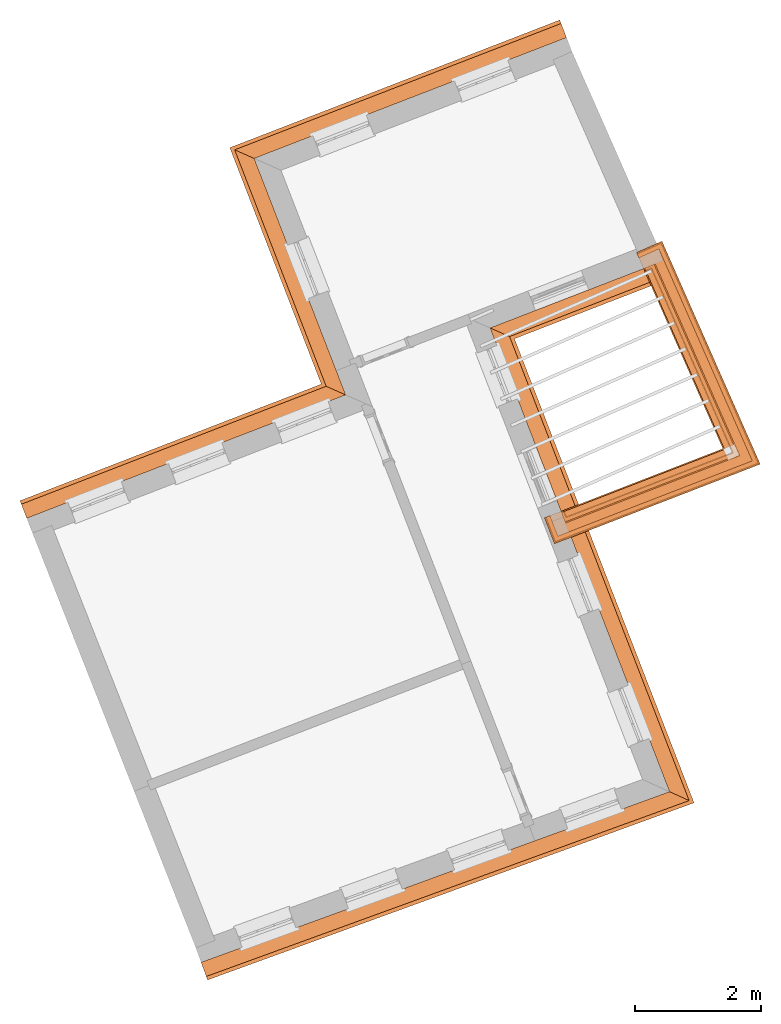
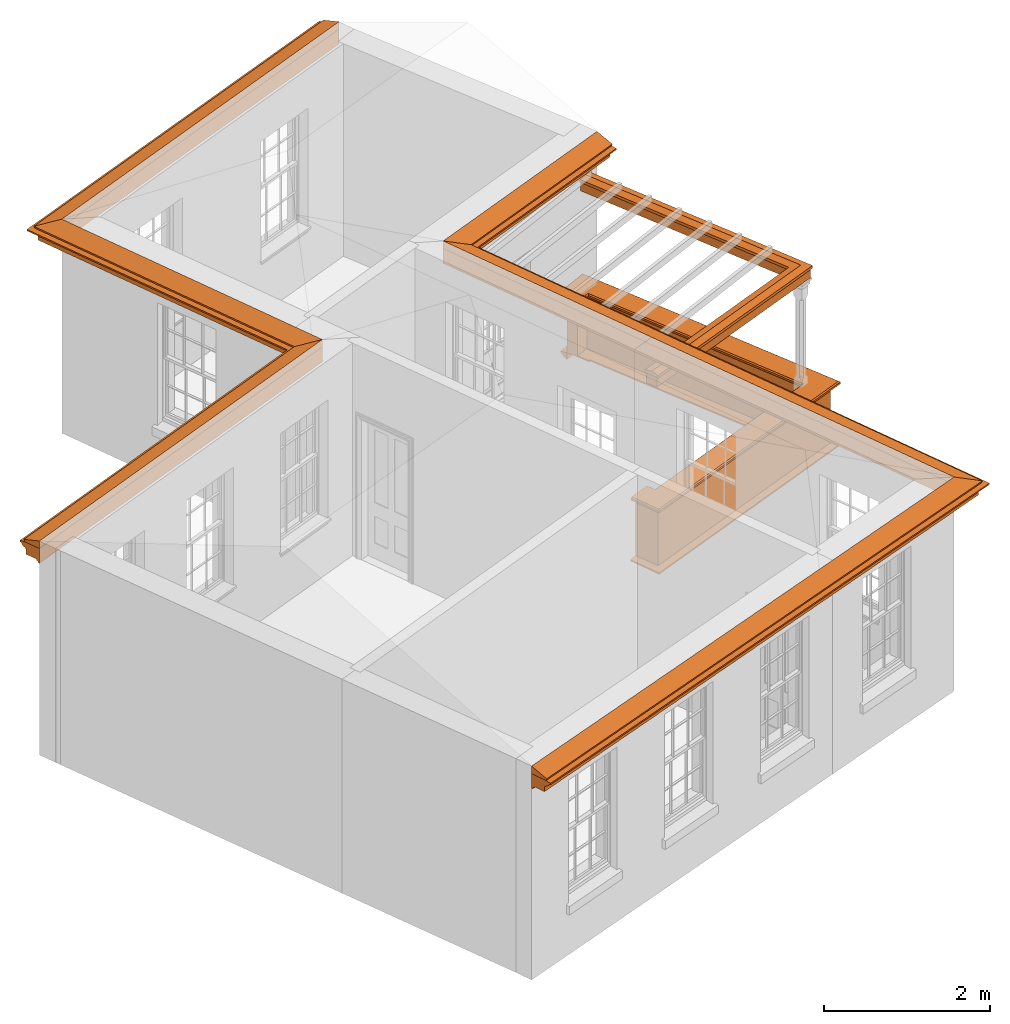
# One storey, part 10 of 11: 9 proxies.
"""IFC2X3 building model written with IfcOpenShell, lengths in metres."""

import ifcopenshell
import ifcopenshell.guid

model = None  # the IFC model being written
_history = None  # IfcOwnerHistory: only IFC2X3 demands one
_inside = {}  # id of a spatial element -> (the spatial element, [elements in it])
_under = {}  # id of a project, library or spatial element -> (it, [spatial elements below it])
_declared = {}  # id of a project -> (the project, [libraries it declares])
_typed = {}  # id of a type object -> (the type object, [elements of that type])
_made_of = {}  # id of a material, layer set ... -> (it, [elements and type objects made of it])


def new_model(schema):
    """Start an empty IFC model of exactly this schema.

    Asked for "IFC4X3", IfcOpenShell would pick the latest addendum, in which some entities
    have other attributes; the version numbers below select the first issue.
    IFC2X3 requires an IfcOwnerHistory on every rooted entity: one is made here for all.
    """
    global model, _history
    if schema == "IFC4X3":
        model = ifcopenshell.file(schema_version=(4, 3, 0, 0))
    else:
        model = ifcopenshell.file(schema=schema)
    _inside.clear()
    _under.clear()
    _declared.clear()
    _typed.clear()
    _made_of.clear()
    _history = None
    if model.schema == "IFC2X3":
        org = make("IfcOrganization", Name="unknown")
        user = make(
            "IfcPersonAndOrganization",
            ThePerson=make("IfcPerson", FamilyName="unknown"),
            TheOrganization=org,
        )
        app = make(
            "IfcApplication",
            ApplicationDeveloper=org,
            Version="unknown",
            ApplicationFullName="unknown",
            ApplicationIdentifier="unknown",
        )
        _history = make(
            "IfcOwnerHistory",
            OwningUser=user,
            OwningApplication=app,
            ChangeAction="ADDED",
            CreationDate=0,
        )
    return model


def make(cls, **values):
    """One entity of the class cls with the attributes given. An attribute that is None is left unset."""
    return model.create_entity(
        cls, **{name: value for name, value in values.items() if value is not None}
    )


def entity(cls, *values):
    """Any entity or typed value of the class cls, its attributes in the order of the schema. None: left unset."""
    e = model.create_entity(cls)
    for i, value in enumerate(values):
        if value is not None:
            e[i] = value
    return e


def rooted(cls, **values):
    """An entity with a GlobalId (a new one), such as an element, a storey or a relation."""
    return make(cls, GlobalId=ifcopenshell.guid.new(), OwnerHistory=_history, **values)


def si_unit(unit_type, name, prefix=None):
    """IfcSIUnit, for example si_unit("LENGTHUNIT", "METRE", prefix="MILLI")."""
    return make("IfcSIUnit", UnitType=unit_type, Prefix=prefix, Name=name)


def assignment(units):
    """IfcUnitAssignment: the units of a project."""
    return None if units is None else make("IfcUnitAssignment", Units=units)


def point(xyz):
    """IfcCartesianPoint."""
    return None if xyz is None else make("IfcCartesianPoint", Coordinates=xyz)


def direction(xyz):
    """IfcDirection."""
    return None if xyz is None else make("IfcDirection", DirectionRatios=xyz)


def frame(location, z_axis=None, x_axis=None):
    """IfcAxis2Placement3D, a coordinate frame: its origin and axes. An axis left out is left unset."""
    return make(
        "IfcAxis2Placement3D",
        Location=point(location),
        Axis=direction(z_axis),
        RefDirection=direction(x_axis),
    )


def origin():
    """The frame at (0, 0, 0) with its axes left unset."""
    return frame((0.0, 0.0, 0.0))


def place(relative_to, where):
    """IfcLocalPlacement: puts the frame where relative to a parent placement (None: the world)."""
    return make(
        "IfcLocalPlacement", PlacementRelTo=relative_to, RelativePlacement=where
    )


def context(
    kind, dimensions, precision=None, world=None, true_north=None, identifier=None
):
    """IfcGeometricRepresentationContext, for example the 3D "Model" context."""
    return make(
        "IfcGeometricRepresentationContext",
        ContextIdentifier=identifier,
        ContextType=kind,
        CoordinateSpaceDimension=dimensions,
        Precision=precision,
        WorldCoordinateSystem=world,
        TrueNorth=true_north,
    )


def subcontext(parent, identifier, kind, view, scale=None):
    """IfcGeometricRepresentationSubContext, for example "Body" below "Model"."""
    return make(
        "IfcGeometricRepresentationSubContext",
        ContextIdentifier=identifier,
        ContextType=kind,
        ParentContext=parent,
        TargetScale=scale,
        TargetView=view,
    )


def project(units=None, contexts=None):
    """IfcProject with its units and contexts."""
    return rooted(
        "IfcProject",
        Name="project",
        RepresentationContexts=contexts,
        UnitsInContext=assignment(units),
    )


def spatial(cls, under=None, at=None, **own):
    """A site, building, storey or space (cls), placed at a placement, below another one or the project."""
    s = rooted(cls, ObjectPlacement=at, **own)
    if under is not None:
        _under.setdefault(under.id(), (under, []))[1].append(s)
    return s


def shape(context_of_items, identifier, shape_type, items):
    """IfcShapeRepresentation: the items that make up one representation, for example the "Body"."""
    return make(
        "IfcShapeRepresentation",
        ContextOfItems=context_of_items,
        RepresentationIdentifier=identifier,
        RepresentationType=shape_type,
        Items=items,
    )


def made_of(thing, what):
    """Note that an element or type object is made of a material, layer set ...; save() writes the relation."""
    if what is not None:
        _made_of.setdefault(what.id(), (what, []))[1].append(thing)
    return thing


def element(
    cls,
    number,
    at=None,
    inside=None,
    cuts=None,
    type_object=None,
    material=None,
    context=None,
    identifier="Body",
    shape_type=None,
    held_by="IfcProductDefinitionShape",
    body=None,
    shapes=None,
    **own,
):
    """One element of the class cls, such as IfcWall. Its Tag is "e" and its number.

    at: its placement. inside: the storey or other place that contains it. cuts: it is an
    opening in that element (IfcRelVoidsElement). A single representation is given by context,
    identifier, shape_type and body (its items); several are given by shapes. held_by: the class
    of the entity that holds the representations. save() writes the other relations.
    """
    e = rooted(cls, Tag="e%d" % number, ObjectPlacement=at, **own)
    if body is not None:
        shapes = [shape(context, identifier, shape_type, body)]
    if shapes is not None:
        e.Representation = make(held_by, Representations=shapes)
    if inside is not None:
        _inside.setdefault(inside.id(), (inside, []))[1].append(e)
    if cuts is not None:
        rooted(
            "IfcRelVoidsElement", RelatingBuildingElement=cuts, RelatedOpeningElement=e
        )
    if type_object is not None:
        _typed.setdefault(type_object.id(), (type_object, []))[1].append(e)
    return made_of(e, material)


def aggregate(whole, parts):
    """IfcRelAggregates: a whole, such as a stair, and the parts it consists of."""
    return rooted("IfcRelAggregates", RelatingObject=whole, RelatedObjects=parts)


def save(model, path):
    """Write the relations noted so far, then the file.

    IfcRelAggregates (storeys below a building ...), IfcRelContainedInSpatialStructure (elements
    in a storey), IfcRelDefinesByType, IfcRelAssociatesMaterial and IfcRelDeclares: one each for
    every whole, place, type object, material and project.
    """
    for whole, parts in _under.values():
        aggregate(whole, parts)
    for where, things in _inside.values():
        rooted(
            "IfcRelContainedInSpatialStructure",
            RelatedElements=things,
            RelatingStructure=where,
        )
    for kind, things in _typed.values():
        rooted("IfcRelDefinesByType", RelatedObjects=things, RelatingType=kind)
    for what, things in _made_of.values():
        rooted("IfcRelAssociatesMaterial", RelatedObjects=things, RelatingMaterial=what)
    for by, libraries in _declared.values():
        rooted("IfcRelDeclares", RelatingContext=by, RelatedDefinitions=libraries)
    model.write(path)


model = new_model("IFC2X3")

# Units and contexts
model_context = context("Model", 3, world=origin())
body_context = subcontext(model_context, "Body", "Model", "MODEL_VIEW")
ifc_project = project(units=[si_unit("PLANEANGLEUNIT", "RADIAN"), si_unit("MASSUNIT", "GRAM", prefix="KILO"), si_unit("FORCEUNIT", "NEWTON", prefix="KILO"), si_unit("LENGTHUNIT", "METRE")], contexts=[model_context])

# Site, building, storey
site_placement = place(None, origin())
site = spatial("IfcSite", under=ifc_project, at=site_placement, CompositionType="ELEMENT")
building_placement = place(None, origin())
building = spatial("IfcBuilding", under=site, at=building_placement, Name="Building plot-5", CompositionType="ELEMENT")
storey_placement = place(None, frame((0.0, 0.0, 7.6)))
storey = spatial("IfcBuildingStorey", under=building, at=storey_placement, Name="Floor 1", CompositionType="ELEMENT", Elevation=7.6)

# Proxies
proxy_1_placement = place(storey_placement, frame((0.0, 0.0, 3.15)))
axis2_placement3_d_1 = entity("IfcAxis2Placement3D", entity("IfcCartesianPoint", [0.0, 0.0, 0.0]))
element("IfcBuildingElementProxy", 1, at=proxy_1_placement, inside=storey, Name="eaves", CompositionType="ELEMENT", context=body_context, shape_type="SweptSolid", held_by="IfcProductRepresentation", body=[
    entity("IfcSurfaceCurveSweptAreaSolid", entity("IfcArbitraryClosedProfileDef", "AREA", None, entity("IfcPolyline", [entity("IfcCartesianPoint", [-0.11, 0.25]), entity("IfcCartesianPoint", [-0.33, 0.25]), entity("IfcCartesianPoint", [-0.33, 0.265]), entity("IfcCartesianPoint", [-0.318, 0.268]), entity("IfcCartesianPoint", [-0.309, 0.274]), entity("IfcCartesianPoint", [-0.303, 0.283]), entity("IfcCartesianPoint", [-0.3, 0.295]), entity("IfcCartesianPoint", [-0.285, 0.295]), entity("IfcCartesianPoint", [-0.285, 0.455]), entity("IfcCartesianPoint", [-0.205, 0.455]), entity("IfcCartesianPoint", [-0.205, 0.47]), entity("IfcCartesianPoint", [-0.19, 0.47]), entity("IfcCartesianPoint", [-0.189, 0.483]), entity("IfcCartesianPoint", [-0.186, 0.494]), entity("IfcCartesianPoint", [-0.179, 0.506]), entity("IfcCartesianPoint", [-0.17, 0.514]), entity("IfcCartesianPoint", [-0.16, 0.52]), entity("IfcCartesianPoint", [-0.149, 0.529]), entity("IfcCartesianPoint", [-0.143, 0.539]), entity("IfcCartesianPoint", [-0.14, 0.55]), entity("IfcCartesianPoint", [-0.12, 0.55]), entity("IfcCartesianPoint", [-0.11, 0.48]), entity("IfcCartesianPoint", [-0.11, 0.25])])), axis2_placement3_d_1, entity("IfcPolyline", [entity("IfcCartesianPoint", [63.5677962418913, 63.5678035343538]), entity("IfcCartesianPoint", [58.8296288626041, 61.7343143929882]), entity("IfcCartesianPoint", [60.2858526496502, 57.9710894635046]), entity("IfcCartesianPoint", [54.9778177025686, 55.9170834188877])]), 0.0, 1.0, entity("IfcPlane", axis2_placement3_d_1)),
])
proxy_2_placement = place(storey_placement, frame((0.0, 0.0, 3.15)))
axis2_placement3_d_2 = entity("IfcAxis2Placement3D", entity("IfcCartesianPoint", [0.0, 0.0, 0.0]))
element("IfcBuildingElementProxy", 2, at=proxy_2_placement, inside=storey, Name="eaves", CompositionType="ELEMENT", context=body_context, shape_type="SweptSolid", held_by="IfcProductRepresentation", body=[
    entity("IfcSurfaceCurveSweptAreaSolid", entity("IfcArbitraryClosedProfileDef", "AREA", None, entity("IfcPolyline", [entity("IfcCartesianPoint", [-0.11, 0.25]), entity("IfcCartesianPoint", [-0.11, 0.48]), entity("IfcCartesianPoint", [-0.08, 0.49]), entity("IfcCartesianPoint", [0.0, 0.25]), entity("IfcCartesianPoint", [-0.11, 0.25])])), axis2_placement3_d_2, entity("IfcPolyline", [entity("IfcCartesianPoint", [63.5677962418913, 63.5678035343538]), entity("IfcCartesianPoint", [58.8296288626041, 61.7343143929882]), entity("IfcCartesianPoint", [60.2858526496502, 57.9710894635046]), entity("IfcCartesianPoint", [54.9778177025686, 55.9170834188877])]), 0.0, 1.0, entity("IfcPlane", axis2_placement3_d_2)),
])
proxy_3_placement = place(storey_placement, frame((0.0, 0.0, 3.15)))
axis2_placement3_d_3 = entity("IfcAxis2Placement3D", entity("IfcCartesianPoint", [0.0, 0.0, 0.0]))
element("IfcBuildingElementProxy", 3, at=proxy_3_placement, inside=storey, Name="eaves", CompositionType="ELEMENT", context=body_context, shape_type="SweptSolid", held_by="IfcProductRepresentation", body=[
    entity("IfcSurfaceCurveSweptAreaSolid", entity("IfcArbitraryClosedProfileDef", "AREA", None, entity("IfcPolyline", [entity("IfcCartesianPoint", [-0.11, 0.25]), entity("IfcCartesianPoint", [-0.33, 0.25]), entity("IfcCartesianPoint", [-0.33, 0.265]), entity("IfcCartesianPoint", [-0.318, 0.268]), entity("IfcCartesianPoint", [-0.309, 0.274]), entity("IfcCartesianPoint", [-0.303, 0.283]), entity("IfcCartesianPoint", [-0.3, 0.295]), entity("IfcCartesianPoint", [-0.285, 0.295]), entity("IfcCartesianPoint", [-0.285, 0.455]), entity("IfcCartesianPoint", [-0.205, 0.455]), entity("IfcCartesianPoint", [-0.205, 0.47]), entity("IfcCartesianPoint", [-0.19, 0.47]), entity("IfcCartesianPoint", [-0.189, 0.483]), entity("IfcCartesianPoint", [-0.186, 0.494]), entity("IfcCartesianPoint", [-0.179, 0.506]), entity("IfcCartesianPoint", [-0.17, 0.514]), entity("IfcCartesianPoint", [-0.16, 0.52]), entity("IfcCartesianPoint", [-0.149, 0.529]), entity("IfcCartesianPoint", [-0.143, 0.539]), entity("IfcCartesianPoint", [-0.14, 0.55]), entity("IfcCartesianPoint", [-0.12, 0.55]), entity("IfcCartesianPoint", [-0.11, 0.48]), entity("IfcCartesianPoint", [-0.11, 0.25])])), axis2_placement3_d_3, entity("IfcPolyline", [entity("IfcCartesianPoint", [57.5763912754506, 49.3189227197573]), entity("IfcCartesianPoint", [64.7915300112382, 51.9466855014291]), entity("IfcCartesianPoint", [61.9373224981561, 59.3226293382876]), entity("IfcCartesianPoint", [64.9284523835962, 60.4800819410264])]), 0.0, 1.0, entity("IfcPlane", axis2_placement3_d_3)),
])
proxy_4_placement = place(storey_placement, frame((0.0, 0.0, 3.15)))
axis2_placement3_d_4 = entity("IfcAxis2Placement3D", entity("IfcCartesianPoint", [0.0, 0.0, 0.0]))
element("IfcBuildingElementProxy", 4, at=proxy_4_placement, inside=storey, Name="eaves", CompositionType="ELEMENT", context=body_context, shape_type="SweptSolid", held_by="IfcProductRepresentation", body=[
    entity("IfcSurfaceCurveSweptAreaSolid", entity("IfcArbitraryClosedProfileDef", "AREA", None, entity("IfcPolyline", [entity("IfcCartesianPoint", [-0.11, 0.25]), entity("IfcCartesianPoint", [-0.11, 0.48]), entity("IfcCartesianPoint", [-0.08, 0.49]), entity("IfcCartesianPoint", [0.0, 0.25]), entity("IfcCartesianPoint", [-0.11, 0.25])])), axis2_placement3_d_4, entity("IfcPolyline", [entity("IfcCartesianPoint", [57.5763912754506, 49.3189227197573]), entity("IfcCartesianPoint", [64.7915300112382, 51.9466855014291]), entity("IfcCartesianPoint", [61.9373224981561, 59.3226293382876]), entity("IfcCartesianPoint", [64.9284523835962, 60.4800819410264])]), 0.0, 1.0, entity("IfcPlane", axis2_placement3_d_4)),
])
proxy_5_placement = place(storey_placement, origin())
axis2_placement3_d_5 = entity("IfcAxis2Placement3D", entity("IfcCartesianPoint", [0.0, 0.0, 0.0]))
element("IfcBuildingElementProxy", 5, at=proxy_5_placement, inside=storey, Name="parapet", CompositionType="ELEMENT", context=body_context, shape_type="SweptSolid", held_by="IfcProductRepresentation", body=[
    entity("IfcSurfaceCurveSweptAreaSolid", entity("IfcArbitraryClosedProfileDef", "AREA", None, entity("IfcPolyline", [entity("IfcCartesianPoint", [0.0, 0.25]), entity("IfcCartesianPoint", [0.795, 0.25]), entity("IfcCartesianPoint", [0.795, 0.09]), entity("IfcCartesianPoint", [0.02, 0.09]), entity("IfcCartesianPoint", [0.02, -0.08]), entity("IfcCartesianPoint", [0.0, -0.08]), entity("IfcCartesianPoint", [0.0, 0.25])])), axis2_placement3_d_5, entity("IfcPolyline", [entity("IfcCartesianPoint", [63.445899617369, 56.2831116335504]), entity("IfcCartesianPoint", [63.4819880690518, 56.189850582435]), entity("IfcCartesianPoint", [66.09972502398, 57.2028144348295]), entity("IfcCartesianPoint", [64.8203071629104, 60.1061829167175]), entity("IfcCartesianPoint", [64.7287981644904, 60.0658579466844])]), 0.0, 1.0, entity("IfcPlane", axis2_placement3_d_5)),
])
proxy_6_placement = place(storey_placement, origin())
axis2_placement3_d_6 = entity("IfcAxis2Placement3D", entity("IfcCartesianPoint", [0.0, 0.0, 0.0]))
element("IfcBuildingElementProxy", 6, at=proxy_6_placement, inside=storey, Name="parapet", CompositionType="ELEMENT", context=body_context, shape_type="SweptSolid", held_by="IfcProductRepresentation", body=[
    entity("IfcSurfaceCurveSweptAreaSolid", entity("IfcArbitraryClosedProfileDef", "AREA", None, entity("IfcPolyline", [entity("IfcCartesianPoint", [0.795, 0.265]), entity("IfcCartesianPoint", [0.807, 0.268]), entity("IfcCartesianPoint", [0.816, 0.274]), entity("IfcCartesianPoint", [0.822, 0.283]), entity("IfcCartesianPoint", [0.825, 0.295]), entity("IfcCartesianPoint", [0.84, 0.295]), entity("IfcCartesianPoint", [0.84, 0.305]), entity("IfcCartesianPoint", [0.842, 0.317]), entity("IfcCartesianPoint", [0.849, 0.326]), entity("IfcCartesianPoint", [0.858, 0.333]), entity("IfcCartesianPoint", [0.87, 0.335]), entity("IfcCartesianPoint", [0.882, 0.333]), entity("IfcCartesianPoint", [0.891, 0.326]), entity("IfcCartesianPoint", [0.898, 0.317]), entity("IfcCartesianPoint", [0.9, 0.305]), entity("IfcCartesianPoint", [0.9, 0.035]), entity("IfcCartesianPoint", [0.898, 0.023]), entity("IfcCartesianPoint", [0.891, 0.014]), entity("IfcCartesianPoint", [0.882, 0.007]), entity("IfcCartesianPoint", [0.87, 0.005]), entity("IfcCartesianPoint", [0.858, 0.007]), entity("IfcCartesianPoint", [0.849, 0.014]), entity("IfcCartesianPoint", [0.842, 0.023]), entity("IfcCartesianPoint", [0.84, 0.035]), entity("IfcCartesianPoint", [0.84, 0.045]), entity("IfcCartesianPoint", [0.825, 0.045]), entity("IfcCartesianPoint", [0.822, 0.057]), entity("IfcCartesianPoint", [0.816, 0.066]), entity("IfcCartesianPoint", [0.807, 0.072]), entity("IfcCartesianPoint", [0.795, 0.075]), entity("IfcCartesianPoint", [0.795, 0.265])])), axis2_placement3_d_6, entity("IfcPolyline", [entity("IfcCartesianPoint", [63.445899617369, 56.2831116335504]), entity("IfcCartesianPoint", [63.4819880690518, 56.189850582435]), entity("IfcCartesianPoint", [66.09972502398, 57.2028144348295]), entity("IfcCartesianPoint", [64.8203071629104, 60.1061829167175]), entity("IfcCartesianPoint", [64.7287981644904, 60.0658579466844])]), 0.0, 1.0, entity("IfcPlane", axis2_placement3_d_6)),
])
proxy_7_placement = place(storey_placement, origin())
axis2_placement3_d_7 = entity("IfcAxis2Placement3D", entity("IfcCartesianPoint", [0.0, 0.0, 0.0]))
element("IfcBuildingElementProxy", 7, at=proxy_7_placement, inside=storey, Name="parapet", CompositionType="ELEMENT", context=body_context, shape_type="SweptSolid", held_by="IfcProductRepresentation", body=[
    entity("IfcSurfaceCurveSweptAreaSolid", entity("IfcArbitraryClosedProfileDef", "AREA", None, entity("IfcPolyline", [entity("IfcCartesianPoint", [-0.1, 0.25]), entity("IfcCartesianPoint", [-0.1, 0.265]), entity("IfcCartesianPoint", [-0.085, 0.265]), entity("IfcCartesianPoint", [-0.084, 0.278]), entity("IfcCartesianPoint", [-0.081, 0.289]), entity("IfcCartesianPoint", [-0.074, 0.301]), entity("IfcCartesianPoint", [-0.065, 0.309]), entity("IfcCartesianPoint", [-0.055, 0.315]), entity("IfcCartesianPoint", [-0.044, 0.324]), entity("IfcCartesianPoint", [-0.038, 0.334]), entity("IfcCartesianPoint", [-0.035, 0.345]), entity("IfcCartesianPoint", [-0.015, 0.345]), entity("IfcCartesianPoint", [0.0, 0.25]), entity("IfcCartesianPoint", [-0.1, 0.25])])), axis2_placement3_d_7, entity("IfcPolyline", [entity("IfcCartesianPoint", [63.445899617369, 56.2831116335504]), entity("IfcCartesianPoint", [63.4819880690518, 56.189850582435]), entity("IfcCartesianPoint", [66.09972502398, 57.2028144348295]), entity("IfcCartesianPoint", [64.8203071629104, 60.1061829167175]), entity("IfcCartesianPoint", [64.7287981644904, 60.0658579466844])]), 0.0, 1.0, entity("IfcPlane", axis2_placement3_d_7)),
])
proxy_8_placement = place(storey_placement, frame((0.0, 0.0, 3.15)))
axis2_placement3_d_8 = entity("IfcAxis2Placement3D", entity("IfcCartesianPoint", [0.0, 0.0, 0.0]))
element("IfcBuildingElementProxy", 8, at=proxy_8_placement, inside=storey, Name="pergola beam", CompositionType="ELEMENT", context=body_context, shape_type="SweptSolid", held_by="IfcProductRepresentation", body=[
    entity("IfcSurfaceCurveSweptAreaSolid", entity("IfcArbitraryClosedProfileDef", "AREA", None, entity("IfcPolyline", [entity("IfcCartesianPoint", [-0.7, -0.08]), entity("IfcCartesianPoint", [-0.7, 0.08]), entity("IfcCartesianPoint", [-0.56, 0.08]), entity("IfcCartesianPoint", [-0.56, -0.08]), entity("IfcCartesianPoint", [-0.7, -0.08])])), axis2_placement3_d_8, entity("IfcPolyline", [entity("IfcCartesianPoint", [63.4260314383826, 56.1681975114254]), entity("IfcCartesianPoint", [66.09972502398, 57.2028144348295]), entity("IfcCartesianPoint", [64.7961121808905, 60.1610883157695])]), 0.0, 1.0, entity("IfcPlane", axis2_placement3_d_8)),
])
proxy_9_placement = place(storey_placement, frame((0.0, 0.0, 3.15)))
axis2_placement3_d_9 = entity("IfcAxis2Placement3D", entity("IfcCartesianPoint", [0.0, 0.0, 0.0]))
element("IfcBuildingElementProxy", 9, at=proxy_9_placement, inside=storey, Name="pergola beam", CompositionType="ELEMENT", context=body_context, shape_type="SweptSolid", held_by="IfcProductRepresentation", body=[
    entity("IfcSurfaceCurveSweptAreaSolid", entity("IfcArbitraryClosedProfileDef", "AREA", None, entity("IfcPolyline", [entity("IfcCartesianPoint", [-0.5, 0.0]), entity("IfcCartesianPoint", [-0.52, -0.1]), entity("IfcCartesianPoint", [-0.56, -0.1]), entity("IfcCartesianPoint", [-0.56, 0.1]), entity("IfcCartesianPoint", [-0.52, 0.1]), entity("IfcCartesianPoint", [-0.5, 0.0])])), axis2_placement3_d_9, entity("IfcPolyline", [entity("IfcCartesianPoint", [63.4260314383826, 56.1681975114254]), entity("IfcCartesianPoint", [66.09972502398, 57.2028144348295]), entity("IfcCartesianPoint", [64.7961121808905, 60.1610883157695])]), 0.0, 1.0, entity("IfcPlane", axis2_placement3_d_9)),
])

save(model, "model.ifc")
